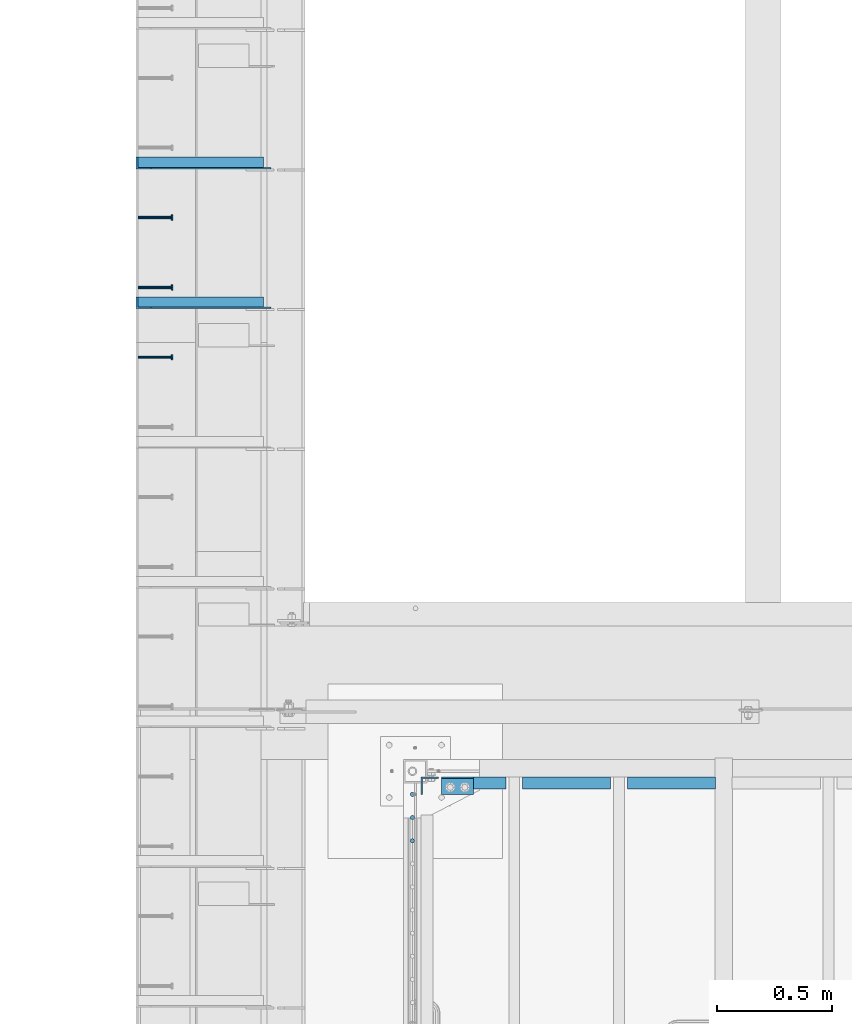
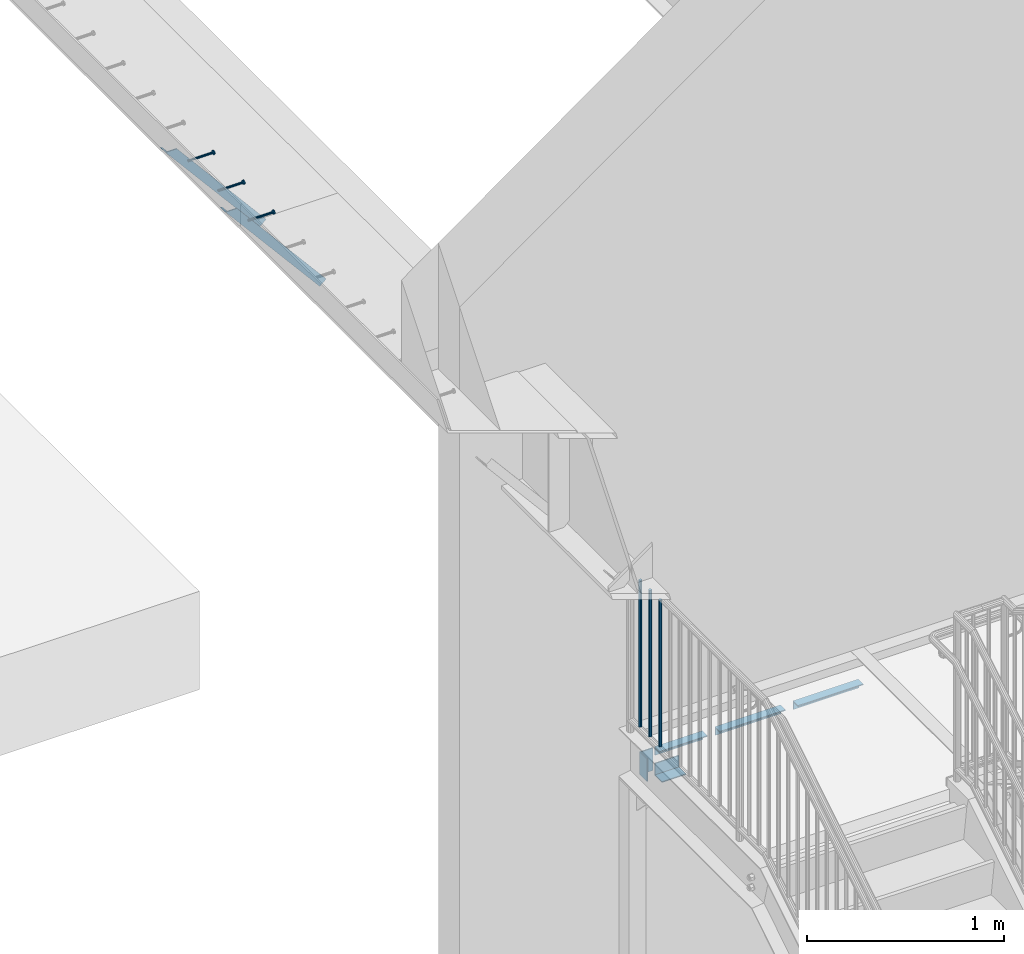
# One storey, part 1277 of 1763: 11 beams, 2 members, 7 elements without a shape of their own.
"""IFC2X3 building model written with IfcOpenShell, lengths in millimetres."""

from ifc_helpers import new_model, si_unit, frame, origin_with_axes, place, context, subcontext, project, spatial, faceted_brep, material, type_object, element, aggregate, save


model = new_model("IFC2X3")

# Units and contexts
model_context = context("Model", 3, precision=1e-05, world=origin_with_axes())
body_context = subcontext(model_context, "Body", "Model", "MODEL_VIEW")
ifc_project = project(units=[si_unit("LENGTHUNIT", "METRE", prefix="MILLI"), si_unit("AREAUNIT", "SQUARE_METRE"), si_unit("VOLUMEUNIT", "CUBIC_METRE"), si_unit("MASSUNIT", "GRAM", prefix="KILO"), si_unit("TIMEUNIT", "SECOND"), si_unit("PLANEANGLEUNIT", "RADIAN"), si_unit("SOLIDANGLEUNIT", "STERADIAN"), si_unit("THERMODYNAMICTEMPERATUREUNIT", "DEGREE_CELSIUS"), si_unit("LUMINOUSINTENSITYUNIT", "LUMEN")], contexts=[model_context])

# Site, building, storey
site_placement = place(None, origin_with_axes())
site = spatial("IfcSite", under=ifc_project, at=site_placement, CompositionType="ELEMENT")
building_placement = place(site_placement, origin_with_axes())
building = spatial("IfcBuilding", under=site, at=building_placement, Name="Undefined", CompositionType="ELEMENT")
storey_placement = place(building_placement, origin_with_axes())
storey = spatial("IfcBuildingStorey", under=building, at=storey_placement, Name="Undefined", CompositionType="ELEMENT", Elevation=0.0)

# Assembly, beam
assembly_1_placement = place(storey_placement, origin_with_axes())
assembly_1 = element("IfcElementAssembly", 1, at=assembly_1_placement, inside=storey, Name="HEADED STUD ANCHOR", AssemblyPlace="NOTDEFINED", PredefinedType="RIGID_FRAME")
ifc_material_1 = material(Name="STEEL/A108")
beam_type_1 = type_object("IfcBeamType", PredefinedType="NOTDEFINED")
beam_1_placement = place(assembly_1_placement, frame((-87975.5122736983, 39106.4750061035, 5268.91250001202), z_axis=(0.0, 0.0, -1.0), x_axis=(1.0, 0.0, 0.0)))
beam_1 = element("IfcBeam", 2, at=beam_1_placement, type_object=beam_type_1, material=ifc_material_1, Name="HEADED STUD ANCHOR", context=body_context, shape_type="Brep", body=[
    faceted_brep([(0.0, -3.1800000667572, 5.5), (0.0, -5.5, 3.1800000667572), (141.732000000002, -5.5, 3.1800000667572), (141.732000000002, -3.1800000667572, 5.5), (0.0, -6.34999999999491, 1.45519152283669e-11), (141.732000000002, -6.34999990463257, 0.0), (0.0, -5.5, -3.1800000667572), (141.732000000002, -5.5, -3.1800000667572), (0.0, -3.1800000667572, -5.5), (141.732000000002, -3.1800000667572, -5.5), (0.0, 0.0, -6.34999990463257), (141.732000000002, 0.0, -6.34999990463257), (0.0, 3.1800000667572, -5.5), (141.732000000002, 3.1800000667572, -5.5), (0.0, 5.5, -3.1800000667572), (141.732000000002, 5.5, -3.1800000667572), (0.0, 6.34999999999491, -2.91038304567337e-11), (141.732000000002, 6.34999990463257, 0.0), (0.0, 5.5, 3.1800000667572), (141.732000000002, 5.5, 3.1800000667572), (0.0, 3.1800000667572, 5.5), (141.732000000002, 3.1800000667572, 5.5), (0.0, 0.0, 6.34999990463257), (141.732000000002, 0.0, 6.34999990463257), (144.780000000001, -10.9899997711182, 6.34999990463257), (144.780000000001, -6.34000015258789, 10.9899997711182), (144.780000000001, -12.6999998092651, 0.0), (144.780000000001, -10.9899997711182, -6.34999990463257), (144.780000000001, -6.34000015258789, -10.9899997711182), (144.780000000001, 0.0, -12.6899995803833), (144.780000000001, 6.34000015258789, -10.9899997711182), (144.780000000001, 10.9899997711182, -6.34999990463257), (144.780000000001, 12.6999998092651, 0.0), (144.780000000001, 10.9899997711182, 6.34999990463257), (144.780000000001, 6.34000015258789, 10.9899997711182), (144.780000000001, 0.0, 12.6899995803833), (152.400000000001, -10.9899997711182, 6.34999990463257), (152.400000000001, -6.34000015258789, 10.9899997711182), (152.400000000001, -12.6999998092651, 0.0), (152.400000000001, -10.9899997711182, -6.34999990463257), (152.400000000001, -6.34000015258789, -10.9899997711182), (152.400000000001, 0.0, -12.6899995803833), (152.400000000001, 6.34000015258789, -10.9899997711182), (152.400000000001, 10.9899997711182, -6.34999990463257), (152.400000000001, 12.6999998092651, 0.0), (152.400000000001, 10.9899997711182, 6.34999990463257), (152.400000000001, 6.34000015258789, 10.9899997711182), (152.400000000001, 0.0, 12.6899995803833)], [[[0, 1, 2, 3]], [[1, 4, 5, 2]], [[4, 6, 7, 5]], [[6, 8, 9, 7]], [[8, 10, 11, 9]], [[10, 12, 13, 11]], [[12, 14, 15, 13]], [[14, 16, 17, 15]], [[16, 18, 19, 17]], [[18, 20, 21, 19]], [[20, 22, 23, 21]], [[22, 0, 3, 23]], [[22, 20, 18, 16, 14, 12, 10, 8, 6, 4, 1, 0]], [[3, 2, 24, 25]], [[2, 5, 26, 24]], [[5, 7, 27, 26]], [[7, 9, 28, 27]], [[9, 11, 29, 28]], [[11, 13, 30, 29]], [[13, 15, 31, 30]], [[15, 17, 32, 31]], [[17, 19, 33, 32]], [[19, 21, 34, 33]], [[21, 23, 35, 34]], [[23, 3, 25, 35]], [[25, 24, 36, 37]], [[24, 26, 38, 36]], [[26, 27, 39, 38]], [[27, 28, 40, 39]], [[28, 29, 41, 40]], [[29, 30, 42, 41]], [[30, 31, 43, 42]], [[31, 32, 44, 43]], [[32, 33, 45, 44]], [[33, 34, 46, 45]], [[34, 35, 47, 46]], [[35, 25, 37, 47]], [[38, 39, 40, 41, 42, 43, 44, 45, 46, 47, 37, 36]]]),
])
aggregate(assembly_1, [beam_1])

assembly_2_placement = place(storey_placement, origin_with_axes())
assembly_2 = element("IfcElementAssembly", 3, at=assembly_2_placement, inside=storey, Name="HEADED STUD ANCHOR", AssemblyPlace="NOTDEFINED", PredefinedType="RIGID_FRAME")
beam_2_placement = place(assembly_2_placement, frame((-87975.5122736983, 39411.2750061035, 5268.91250001202), z_axis=(0.0, 0.0, -1.0), x_axis=(1.0, 0.0, 0.0)))
beam_2 = element("IfcBeam", 4, at=beam_2_placement, type_object=beam_type_1, material=ifc_material_1, Name="HEADED STUD ANCHOR", context=body_context, shape_type="Brep", body=[
    faceted_brep([(0.0, -3.1800000667572, 5.5), (0.0, -5.5, 3.1800000667572), (141.732000000002, -5.5, 3.1800000667572), (141.732000000002, -3.1800000667572, 5.5), (0.0, -6.34999999999491, 1.45519152283669e-11), (141.732000000002, -6.34999990463257, 0.0), (0.0, -5.5, -3.1800000667572), (141.732000000002, -5.5, -3.1800000667572), (0.0, -3.1800000667572, -5.5), (141.732000000002, -3.1800000667572, -5.5), (0.0, 0.0, -6.34999990463257), (141.732000000002, 0.0, -6.34999990463257), (0.0, 3.1800000667572, -5.5), (141.732000000002, 3.1800000667572, -5.5), (0.0, 5.5, -3.1800000667572), (141.732000000002, 5.5, -3.1800000667572), (0.0, 6.34999999999491, -2.91038304567337e-11), (141.732000000002, 6.34999990463257, 0.0), (0.0, 5.5, 3.1800000667572), (141.732000000002, 5.5, 3.1800000667572), (0.0, 3.1800000667572, 5.5), (141.732000000002, 3.1800000667572, 5.5), (0.0, 0.0, 6.34999990463257), (141.732000000002, 0.0, 6.34999990463257), (144.780000000001, -10.9899997711182, 6.34999990463257), (144.780000000001, -6.34000015258789, 10.9899997711182), (144.780000000001, -12.6999998092651, 0.0), (144.780000000001, -10.9899997711182, -6.34999990463257), (144.780000000001, -6.34000015258789, -10.9899997711182), (144.780000000001, 0.0, -12.6899995803833), (144.780000000001, 6.34000015258789, -10.9899997711182), (144.780000000001, 10.9899997711182, -6.34999990463257), (144.780000000001, 12.6999998092651, 0.0), (144.780000000001, 10.9899997711182, 6.34999990463257), (144.780000000001, 6.34000015258789, 10.9899997711182), (144.780000000001, 0.0, 12.6899995803833), (152.400000000001, -10.9899997711182, 6.34999990463257), (152.400000000001, -6.34000015258789, 10.9899997711182), (152.400000000001, -12.6999998092651, 0.0), (152.400000000001, -10.9899997711182, -6.34999990463257), (152.400000000001, -6.34000015258789, -10.9899997711182), (152.400000000001, 0.0, -12.6899995803833), (152.400000000001, 6.34000015258789, -10.9899997711182), (152.400000000001, 10.9899997711182, -6.34999990463257), (152.400000000001, 12.6999998092651, 0.0), (152.400000000001, 10.9899997711182, 6.34999990463257), (152.400000000001, 6.34000015258789, 10.9899997711182), (152.400000000001, 0.0, 12.6899995803833)], [[[0, 1, 2, 3]], [[1, 4, 5, 2]], [[4, 6, 7, 5]], [[6, 8, 9, 7]], [[8, 10, 11, 9]], [[10, 12, 13, 11]], [[12, 14, 15, 13]], [[14, 16, 17, 15]], [[16, 18, 19, 17]], [[18, 20, 21, 19]], [[20, 22, 23, 21]], [[22, 0, 3, 23]], [[22, 20, 18, 16, 14, 12, 10, 8, 6, 4, 1, 0]], [[3, 2, 24, 25]], [[2, 5, 26, 24]], [[5, 7, 27, 26]], [[7, 9, 28, 27]], [[9, 11, 29, 28]], [[11, 13, 30, 29]], [[13, 15, 31, 30]], [[15, 17, 32, 31]], [[17, 19, 33, 32]], [[19, 21, 34, 33]], [[21, 23, 35, 34]], [[23, 3, 25, 35]], [[25, 24, 36, 37]], [[24, 26, 38, 36]], [[26, 27, 39, 38]], [[27, 28, 40, 39]], [[28, 29, 41, 40]], [[29, 30, 42, 41]], [[30, 31, 43, 42]], [[31, 32, 44, 43]], [[32, 33, 45, 44]], [[33, 34, 46, 45]], [[34, 35, 47, 46]], [[35, 25, 37, 47]], [[38, 39, 40, 41, 42, 43, 44, 45, 46, 47, 37, 36]]]),
])
aggregate(assembly_2, [beam_2])

assembly_3_placement = place(storey_placement, origin_with_axes())
assembly_3 = element("IfcElementAssembly", 5, at=assembly_3_placement, inside=storey, Name="HEADED STUD ANCHOR", AssemblyPlace="NOTDEFINED", PredefinedType="RIGID_FRAME")
beam_3_placement = place(assembly_3_placement, frame((-87975.5122736983, 39716.0750061035, 5268.91250001202), z_axis=(0.0, 0.0, -1.0), x_axis=(1.0, 0.0, 0.0)))
beam_3 = element("IfcBeam", 6, at=beam_3_placement, type_object=beam_type_1, material=ifc_material_1, Name="HEADED STUD ANCHOR", context=body_context, shape_type="Brep", body=[
    faceted_brep([(0.0, -3.1800000667572, 5.5), (0.0, -5.5, 3.1800000667572), (141.732000000002, -5.5, 3.1800000667572), (141.732000000002, -3.1800000667572, 5.5), (0.0, -6.34999999999491, 1.45519152283669e-11), (141.732000000002, -6.34999990463257, 0.0), (0.0, -5.5, -3.1800000667572), (141.732000000002, -5.5, -3.1800000667572), (0.0, -3.1800000667572, -5.5), (141.732000000002, -3.1800000667572, -5.5), (0.0, 0.0, -6.34999990463257), (141.732000000002, 0.0, -6.34999990463257), (0.0, 3.1800000667572, -5.5), (141.732000000002, 3.1800000667572, -5.5), (0.0, 5.5, -3.1800000667572), (141.732000000002, 5.5, -3.1800000667572), (0.0, 6.34999999999491, -2.91038304567337e-11), (141.732000000002, 6.34999990463257, 0.0), (0.0, 5.5, 3.1800000667572), (141.732000000002, 5.5, 3.1800000667572), (0.0, 3.1800000667572, 5.5), (141.732000000002, 3.1800000667572, 5.5), (0.0, 0.0, 6.34999990463257), (141.732000000002, 0.0, 6.34999990463257), (144.780000000001, -10.9899997711182, 6.34999990463257), (144.780000000001, -6.34000015258789, 10.9899997711182), (144.780000000001, -12.6999998092651, 0.0), (144.780000000001, -10.9899997711182, -6.34999990463257), (144.780000000001, -6.34000015258789, -10.9899997711182), (144.780000000001, 0.0, -12.6899995803833), (144.780000000001, 6.34000015258789, -10.9899997711182), (144.780000000001, 10.9899997711182, -6.34999990463257), (144.780000000001, 12.6999998092651, 0.0), (144.780000000001, 10.9899997711182, 6.34999990463257), (144.780000000001, 6.34000015258789, 10.9899997711182), (144.780000000001, 0.0, 12.6899995803833), (152.400000000001, -10.9899997711182, 6.34999990463257), (152.400000000001, -6.34000015258789, 10.9899997711182), (152.400000000001, -12.6999998092651, 0.0), (152.400000000001, -10.9899997711182, -6.34999990463257), (152.400000000001, -6.34000015258789, -10.9899997711182), (152.400000000001, 0.0, -12.6899995803833), (152.400000000001, 6.34000015258789, -10.9899997711182), (152.400000000001, 10.9899997711182, -6.34999990463257), (152.400000000001, 12.6999998092651, 0.0), (152.400000000001, 10.9899997711182, 6.34999990463257), (152.400000000001, 6.34000015258789, 10.9899997711182), (152.400000000001, 0.0, 12.6899995803833)], [[[0, 1, 2, 3]], [[1, 4, 5, 2]], [[4, 6, 7, 5]], [[6, 8, 9, 7]], [[8, 10, 11, 9]], [[10, 12, 13, 11]], [[12, 14, 15, 13]], [[14, 16, 17, 15]], [[16, 18, 19, 17]], [[18, 20, 21, 19]], [[20, 22, 23, 21]], [[22, 0, 3, 23]], [[22, 20, 18, 16, 14, 12, 10, 8, 6, 4, 1, 0]], [[3, 2, 24, 25]], [[2, 5, 26, 24]], [[5, 7, 27, 26]], [[7, 9, 28, 27]], [[9, 11, 29, 28]], [[11, 13, 30, 29]], [[13, 15, 31, 30]], [[15, 17, 32, 31]], [[17, 19, 33, 32]], [[19, 21, 34, 33]], [[21, 23, 35, 34]], [[23, 3, 25, 35]], [[25, 24, 36, 37]], [[24, 26, 38, 36]], [[26, 27, 39, 38]], [[27, 28, 40, 39]], [[28, 29, 41, 40]], [[29, 30, 42, 41]], [[30, 31, 43, 42]], [[31, 32, 44, 43]], [[32, 33, 45, 44]], [[33, 34, 46, 45]], [[34, 35, 47, 46]], [[35, 25, 37, 47]], [[38, 39, 40, 41, 42, 43, 44, 45, 46, 47, 37, 36]]]),
])
aggregate(assembly_3, [beam_3])

# Assembly, members
assembly_4_placement = place(storey_placement, origin_with_axes())
assembly_4 = element("IfcElementAssembly", 7, at=assembly_4_placement, inside=storey, Name="BEAM", AssemblyPlace="NOTDEFINED", PredefinedType="RIGID_FRAME")
ifc_material_2 = material(Name="STEEL/A36")
member_type = type_object("IfcMemberType", Name="L2X2X1/4", PredefinedType="NOTDEFINED")
member_1_placement = place(assembly_4_placement, frame((-87414.1929584935, 39954.2, 4557.35349338836), z_axis=(0.764183480307171, 0.0, 0.644998921259268), x_axis=(-0.644998921259266, 0.0, 0.764183480307173)))
member_1 = element("IfcMember", 8, at=member_1_placement, type_object=member_type, material=ifc_material_2, Name="ANGLE", ObjectType="L2X2X1/4", context=body_context, shape_type="Brep", body=[
    faceted_brep([(-1.45519152283669e-11, 25.4000000000015, -25.3999999999869), (1.45519152283669e-11, 25.4000000000015, 25.3999999999796), (812.060911532491, 25.4000000000015, 25.400000001966), (854.937976763787, 25.4000000000015, -25.3999999979424), (1.45519152283669e-11, 19.0499999999993, 25.3999999999796), (812.060911532491, 19.0500000000029, 25.400000001966), (-7.27595761418343e-12, 19.0499999999993, -19.0499999999956), (849.578343609872, 19.0500000000029, -19.0499999979511), (-7.27595761418343e-12, -25.4000000000015, -19.0499999999956), (849.578343609872, -25.4000000000015, -19.0499999979511), (-1.45519152283669e-11, -25.4000000000015, -25.3999999999869), (854.937976763787, -25.4000000000015, -25.3999999979424)], [[[0, 1, 2, 3]], [[1, 4, 5, 2]], [[4, 6, 7, 5]], [[6, 8, 9, 7]], [[8, 10, 11, 9]], [[10, 0, 3, 11]], [[5, 7, 9, 11, 3, 2]], [[10, 8, 6, 4, 1, 0]]]),
])
member_2_placement = place(assembly_4_placement, frame((-87414.1929584935, 39344.6, 4557.35349338836), z_axis=(0.764183480307171, 0.0, 0.644998921259268), x_axis=(-0.644998921259266, 0.0, 0.764183480307173)))
member_2 = element("IfcMember", 9, at=member_2_placement, type_object=member_type, material=ifc_material_2, Name="ANGLE", ObjectType="L2X2X1/4", context=body_context, shape_type="Brep", body=[
    faceted_brep([(-1.45519152283669e-11, 25.4000000000015, -25.3999999999869), (1.45519152283669e-11, 25.4000000000015, 25.3999999999796), (812.060911532491, 25.4000000000015, 25.400000001966), (854.937976763787, 25.4000000000015, -25.3999999979424), (1.45519152283669e-11, 19.0499999999993, 25.3999999999796), (812.060911532491, 19.0500000000029, 25.400000001966), (-7.27595761418343e-12, 19.0499999999993, -19.0499999999956), (849.578343609872, 19.0500000000029, -19.0499999979511), (-7.27595761418343e-12, -25.4000000000015, -19.0499999999956), (849.578343609872, -25.4000000000015, -19.0499999979511), (-1.45519152283669e-11, -25.4000000000015, -25.3999999999869), (854.937976763787, -25.4000000000015, -25.3999999979424)], [[[0, 1, 2, 3]], [[1, 4, 5, 2]], [[4, 6, 7, 5]], [[6, 8, 9, 7]], [[8, 10, 11, 9]], [[10, 0, 3, 11]], [[5, 7, 9, 11, 3, 2]], [[10, 8, 6, 4, 1, 0]]]),
])
aggregate(assembly_4, [member_1, member_2])

# Assembly, beams
assembly_5_placement = place(storey_placement, origin_with_axes())
assembly_5 = element("IfcElementAssembly", 10, at=assembly_5_placement, inside=storey, Name="STRINGER", AssemblyPlace="NOTDEFINED", PredefinedType="RIGID_FRAME")
beam_type_2 = type_object("IfcBeamType", Name="L2X2X1/4", PredefinedType="NOTDEFINED")
beam_4_placement = place(assembly_5_placement, frame((-85456.1499998093, 37249.1000000016, 2630.48749999996), z_axis=(0.0, 0.0, -1.0), x_axis=(-1.0, 0.0, 0.0)))
beam_4 = element("IfcBeam", 11, at=beam_4_placement, type_object=beam_type_2, material=ifc_material_2, Name="ANGLE", ObjectType="L2X2X1/4", context=body_context, shape_type="Brep", body=[
    faceted_brep([(-1.45519152283669e-11, 25.4000000000015, -25.3999999999869), (1.45519152283669e-11, 25.4000000000015, 25.3999999999796), (384.10862775179, 25.4000000000015, 25.4000000000001), (384.10862775179, 25.4000000000015, -25.4000000000001), (1.45519152283669e-11, 19.0499999999993, 25.3999999999796), (384.10862775179, 19.0500000000029, 25.4000000000001), (-7.27595761418343e-12, 19.0499999999993, -19.0499999999956), (384.10862775179, 19.0500000000029, -19.0500000000002), (-7.27595761418343e-12, -25.4000000000015, -19.0499999999956), (384.10862775179, -25.4000000000015, -19.0500000000002), (-1.45519152283669e-11, -25.4000000000015, -25.3999999999869), (384.10862775179, -25.4000000000015, -25.4000000000001)], [[[0, 1, 2, 3]], [[1, 4, 5, 2]], [[4, 6, 7, 5]], [[6, 8, 9, 7]], [[8, 10, 11, 9]], [[10, 0, 3, 11]], [[5, 7, 9, 11, 3, 2]], [[10, 8, 6, 4, 1, 0]]]),
])
beam_5_placement = place(assembly_5_placement, frame((-85913.2836271796, 37249.1000000016, 2630.48749999995), z_axis=(0.0, 0.0, -1.0), x_axis=(-1.0, 0.0, 0.0)))
beam_5 = element("IfcBeam", 12, at=beam_5_placement, type_object=beam_type_2, material=ifc_material_2, Name="ANGLE", ObjectType="L2X2X1/4", context=body_context, shape_type="Brep", body=[
    faceted_brep([(-1.45519152283669e-11, 25.4000000000015, -25.3999999999869), (1.45519152283669e-11, 25.4000000000015, 25.3999999999796), (384.307732435307, 25.4000000000015, 25.4000000000001), (384.307732435307, 25.4000000000015, -25.4000000000001), (1.45519152283669e-11, 19.0499999999993, 25.3999999999796), (384.307732435307, 19.0500000000029, 25.4000000000001), (-7.27595761418343e-12, 19.0499999999993, -19.0499999999956), (384.307732435307, 19.0500000000029, -19.0500000000002), (-7.27595761418343e-12, -25.4000000000015, -19.0499999999956), (384.307732435307, -25.4000000000015, -19.0500000000002), (-1.45519152283669e-11, -25.4000000000015, -25.3999999999869), (384.307732435307, -25.4000000000015, -25.4000000000001)], [[[0, 1, 2, 3]], [[1, 4, 5, 2]], [[4, 6, 7, 5]], [[6, 8, 9, 7]], [[8, 10, 11, 9]], [[10, 0, 3, 11]], [[5, 7, 9, 11, 3, 2]], [[10, 8, 6, 4, 1, 0]]]),
])
beam_6_placement = place(assembly_5_placement, frame((-86370.0206068378, 37249.1000000016, 2630.48749999995), z_axis=(0.0, 0.0, -1.0), x_axis=(-1.0, 0.0, 0.0)))
beam_6 = element("IfcBeam", 13, at=beam_6_placement, type_object=beam_type_2, material=ifc_material_2, Name="ANGLE", ObjectType="L2X2X1/4", context=body_context, shape_type="Brep", body=[
    faceted_brep([(-1.45519152283669e-11, 25.4000000000015, -25.3999999999869), (1.45519152283669e-11, 25.4000000000015, 25.3999999999796), (281.516667138974, 25.4000000000015, 25.4000000000001), (281.516667138974, 25.4000000000015, -25.4000000000001), (1.45519152283669e-11, 19.0499999999993, 25.3999999999796), (281.516667138974, 19.0500000000029, 25.4000000000001), (-7.27595761418343e-12, 19.0499999999993, -19.0499999999956), (281.516667138974, 19.0500000000029, -19.0500000000002), (-7.27595761418343e-12, -25.4000000000015, -19.0499999999956), (281.516667138974, -25.4000000000015, -19.0500000000002), (-1.45519152283669e-11, -25.4000000000015, -25.3999999999869), (281.516667138974, -25.4000000000015, -25.4000000000001)], [[[0, 1, 2, 3]], [[1, 4, 5, 2]], [[4, 6, 7, 5]], [[6, 8, 9, 7]], [[8, 10, 11, 9]], [[10, 0, 3, 11]], [[5, 7, 9, 11, 3, 2]], [[10, 8, 6, 4, 1, 0]]]),
])

assembly_6_placement = place(storey_placement, origin_with_axes())
assembly_6 = element("IfcElementAssembly", 14, at=assembly_6_placement, inside=storey, Name="RAIL", AssemblyPlace="NOTDEFINED", PredefinedType="RIGID_FRAME")
beam_type_3 = type_object("IfcBeamType", PredefinedType="NOTDEFINED")
beam_7_placement = place(assembly_6_placement, frame((-86778.5372736927, 37198.992727642, 3798.8875000151), z_axis=(-1.0, 0.0, 0.0), x_axis=(0.0, 0.0, -1.0)))
beam_7 = element("IfcBeam", 15, at=beam_7_placement, type_object=beam_type_3, material=ifc_material_2, Name="PICKET", context=body_context, shape_type="Brep", body=[
    faceted_brep([(19.0499999999092, -9.52500000000146, 0.0), (19.0499999999092, -6.73519209080405, -6.73519209079677), (927.099999996084, -6.73519209080405, -6.73519209079677), (927.099999996084, -9.52500000000146, 0.0), (19.0499999999092, 0.0, -9.52499999999418), (927.099999996084, 0.0, -9.52499999999418), (19.0499999999092, 6.73519209080405, -6.73519209079677), (927.099999996084, 6.73519209080405, -6.73519209079677), (19.0499999999092, 9.52500000000146, 0.0), (927.099999996084, 9.52500000000146, 0.0), (19.0499999999092, 6.73519209080405, 6.73519209079677), (927.099999996084, 6.73519209080405, 6.73519209079677), (19.0499999999092, 0.0, 9.52499999999418), (927.099999996084, 0.0, 9.52499999999418), (19.0499999999092, -6.73519209080405, 6.73519209079677), (927.099999996084, -6.73519209080405, 6.73519209079677)], [[[0, 1, 2, 3]], [[1, 4, 5, 2]], [[4, 6, 7, 5]], [[6, 8, 9, 7]], [[8, 10, 11, 9]], [[10, 12, 13, 11]], [[12, 14, 15, 13]], [[14, 0, 3, 15]], [[5, 7, 9, 11, 13, 15, 3, 2]], [[14, 12, 10, 8, 6, 4, 1, 0]]]),
])
beam_8_placement = place(assembly_6_placement, frame((-86778.5372736927, 37098.0854549147, 3798.8875000151), z_axis=(-1.0, 0.0, 0.0), x_axis=(0.0, 0.0, -1.0)))
beam_8 = element("IfcBeam", 16, at=beam_8_placement, type_object=beam_type_3, material=ifc_material_2, Name="PICKET", context=body_context, shape_type="Brep", body=[
    faceted_brep([(19.0499999999092, -9.52500000000146, 0.0), (19.0499999999092, -6.73519209080405, -6.73519209079677), (927.099999996084, -6.73519209080405, -6.73519209079677), (927.099999996084, -9.52500000000146, 0.0), (19.0499999999092, 0.0, -9.52499999999418), (927.099999996084, 0.0, -9.52499999999418), (19.0499999999092, 6.73519209080405, -6.73519209079677), (927.099999996084, 6.73519209080405, -6.73519209079677), (19.0499999999092, 9.52500000000146, 0.0), (927.099999996084, 9.52500000000146, 0.0), (19.0499999999092, 6.73519209080405, 6.73519209079677), (927.099999996084, 6.73519209080405, 6.73519209079677), (19.0499999999092, 0.0, 9.52499999999418), (927.099999996084, 0.0, 9.52499999999418), (19.0499999999092, -6.73519209080405, 6.73519209079677), (927.099999996084, -6.73519209080405, 6.73519209079677)], [[[0, 1, 2, 3]], [[1, 4, 5, 2]], [[4, 6, 7, 5]], [[6, 8, 9, 7]], [[8, 10, 11, 9]], [[10, 12, 13, 11]], [[12, 14, 15, 13]], [[14, 0, 3, 15]], [[5, 7, 9, 11, 13, 15, 3, 2]], [[14, 12, 10, 8, 6, 4, 1, 0]]]),
])
beam_9_placement = place(assembly_6_placement, frame((-86778.5372736927, 36997.1781821875, 3798.8875000151), z_axis=(-1.0, 0.0, 0.0), x_axis=(0.0, 0.0, -1.0)))
beam_9 = element("IfcBeam", 17, at=beam_9_placement, type_object=beam_type_3, material=ifc_material_2, Name="PICKET", context=body_context, shape_type="Brep", body=[
    faceted_brep([(19.0499999999092, -9.52500000000146, 0.0), (19.0499999999092, -6.73519209080405, -6.73519209079677), (927.099999996084, -6.73519209080405, -6.73519209079677), (927.099999996084, -9.52500000000146, 0.0), (19.0499999999092, 0.0, -9.52499999999418), (927.099999996084, 0.0, -9.52499999999418), (19.0499999999092, 6.73519209080405, -6.73519209079677), (927.099999996084, 6.73519209080405, -6.73519209079677), (19.0499999999092, 9.52500000000146, 0.0), (927.099999996084, 9.52500000000146, 0.0), (19.0499999999092, 6.73519209080405, 6.73519209079677), (927.099999996084, 6.73519209080405, 6.73519209079677), (19.0499999999092, 0.0, 9.52499999999418), (927.099999996084, 0.0, 9.52499999999418), (19.0499999999092, -6.73519209080405, 6.73519209079677), (927.099999996084, -6.73519209080405, 6.73519209079677)], [[[0, 1, 2, 3]], [[1, 4, 5, 2]], [[4, 6, 7, 5]], [[6, 8, 9, 7]], [[8, 10, 11, 9]], [[10, 12, 13, 11]], [[12, 14, 15, 13]], [[14, 0, 3, 15]], [[5, 7, 9, 11, 13, 15, 3, 2]], [[14, 12, 10, 8, 6, 4, 1, 0]]]),
])
aggregate(assembly_6, [beam_7, beam_8, beam_9])

# Beam
beam_type_4 = type_object("IfcBeamType", Name="L3X3X1/4", PredefinedType="NOTDEFINED")
beam_10_placement = place(assembly_5_placement, frame((-86511.8372737318, 37236.4000000016, 2516.18750001402), z_axis=(0.0, -1.0, 0.0), x_axis=(-1.0, 0.0, 0.0)))
beam_10 = element("IfcBeam", 18, at=beam_10_placement, type_object=beam_type_4, material=ifc_material_2, Name="ANGLE", ObjectType="L3X3X1/4", context=body_context, shape_type="Brep", body=[
    faceted_brep([(0.0, 38.0999999999985, -38.1000000000004), (0.0, 38.0999999999985, 38.1000000000004), (139.699999999999, 38.1000000000058, 38.0999999999985), (139.699999999999, 38.1000000000058, -38.0999999999985), (0.0, 31.75, 38.1000000000058), (139.699999999999, 31.75, 38.0999999999985), (0.0, 31.75, -31.75), (139.699999999999, 31.75, -31.75), (0.0, -38.1000000000004, -31.75), (139.699999999999, -38.1000000000058, -31.75), (0.0, -38.0999999999985, -38.1000000000004), (139.699999999999, -38.1000000000058, -38.0999999999985)], [[[0, 1, 2, 3]], [[1, 4, 5, 2]], [[4, 6, 7, 5]], [[6, 8, 9, 7]], [[8, 10, 11, 9]], [[10, 0, 3, 11]], [[5, 7, 9, 11, 3, 2]], [[10, 8, 6, 4, 1, 0]]]),
])

aggregate(assembly_5, [beam_10, beam_4, beam_5, beam_6])

# Assembly, beam
assembly_7_placement = place(storey_placement, origin_with_axes())
assembly_7 = element("IfcElementAssembly", 19, at=assembly_7_placement, inside=storey, Name="STRINGER", AssemblyPlace="NOTDEFINED", PredefinedType="RIGID_FRAME")
beam_11_placement = place(assembly_7_placement, frame((-86702.337273786, 37236.4000000016, 2655.88750001402), z_axis=(1.0, 0.0, 0.0), x_axis=(0.0, 0.0, -1.0)))
beam_11 = element("IfcBeam", 20, at=beam_11_placement, type_object=beam_type_4, material=ifc_material_2, Name="ANGLE", ObjectType="L3X3X1/4", context=body_context, shape_type="Brep", body=[
    faceted_brep([(0.0, 38.0999999999985, -38.1000000000004), (0.0, 38.0999999999985, 38.1000000000004), (139.699999999999, 38.1000000000058, 38.0999999999985), (139.699999999999, 38.1000000000058, -38.0999999999985), (0.0, 31.75, 38.1000000000058), (139.699999999999, 31.75, 38.0999999999985), (0.0, 31.75, -31.75), (139.699999999999, 31.75, -31.75), (0.0, -38.1000000000004, -31.75), (139.699999999999, -38.1000000000058, -31.75), (0.0, -38.0999999999985, -38.1000000000004), (139.699999999999, -38.1000000000058, -38.0999999999985)], [[[0, 1, 2, 3]], [[1, 4, 5, 2]], [[4, 6, 7, 5]], [[6, 8, 9, 7]], [[8, 10, 11, 9]], [[10, 0, 3, 11]], [[5, 7, 9, 11, 3, 2]], [[10, 8, 6, 4, 1, 0]]]),
])
aggregate(assembly_7, [beam_11])

save(model, "model.ifc")
